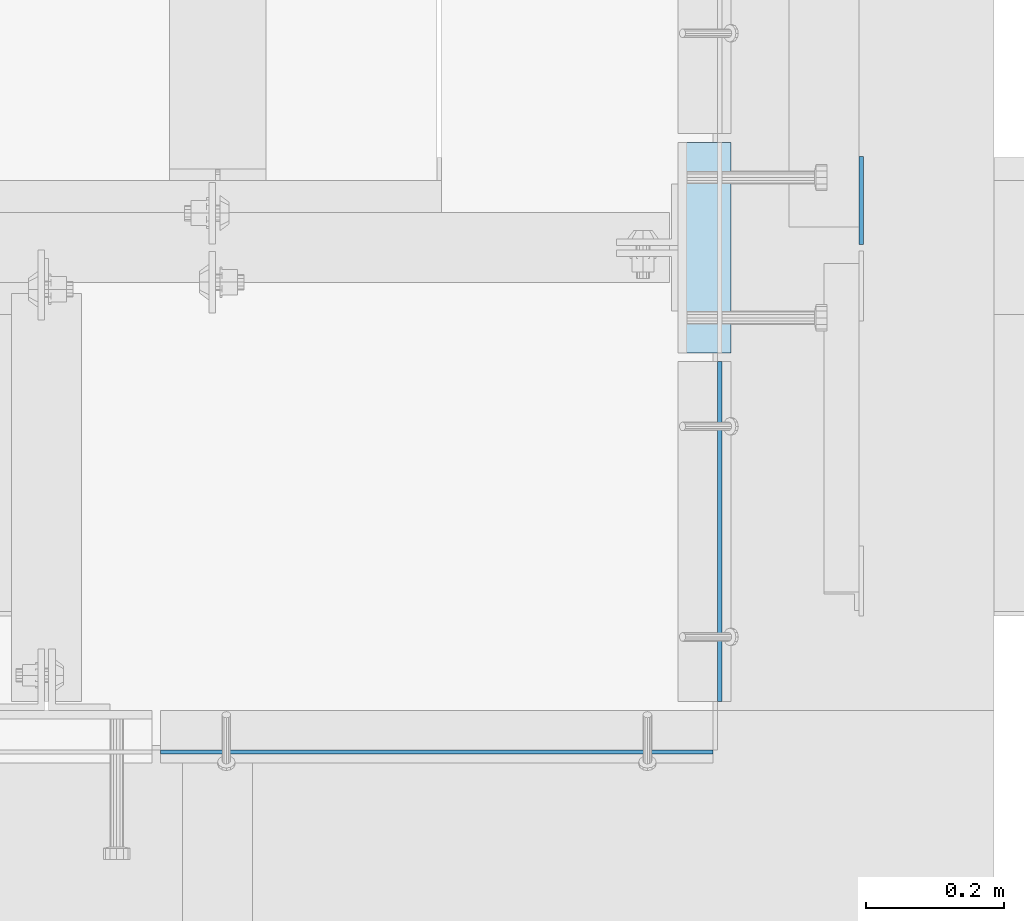
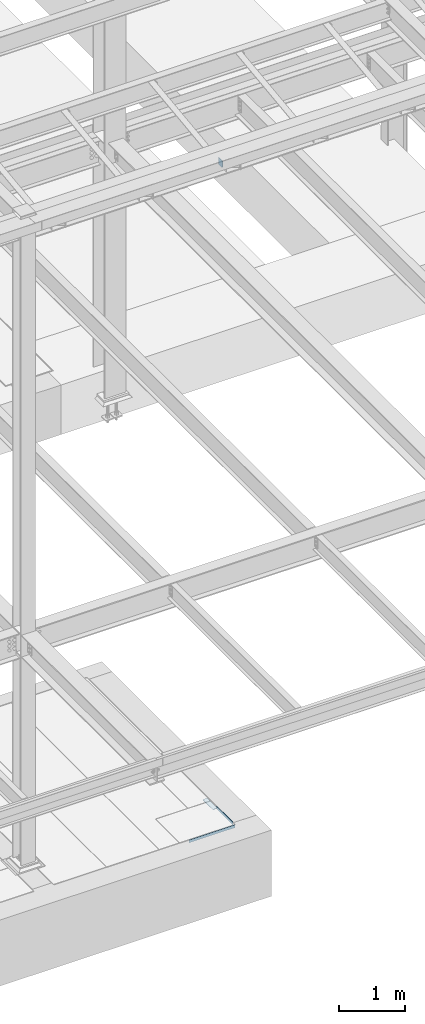
# One storey, part 3083 of 3843: 4 plates, 4 elements without a shape of their own.
"""IFC2X3 building model written with IfcOpenShell, lengths in millimetres."""

from ifc_helpers import new_model, si_unit, frame, origin_with_axes, place, context, subcontext, project, spatial, faceted_brep, material, type_object, element, aggregate, save


model = new_model("IFC2X3")

# Units and contexts
model_context = context("Model", 3, precision=1e-05, world=origin_with_axes())
body_context = subcontext(model_context, "Body", "Model", "MODEL_VIEW")
ifc_project = project(units=[si_unit("LENGTHUNIT", "METRE", prefix="MILLI"), si_unit("AREAUNIT", "SQUARE_METRE"), si_unit("VOLUMEUNIT", "CUBIC_METRE"), si_unit("MASSUNIT", "GRAM", prefix="KILO"), si_unit("TIMEUNIT", "SECOND"), si_unit("PLANEANGLEUNIT", "RADIAN"), si_unit("SOLIDANGLEUNIT", "STERADIAN"), si_unit("THERMODYNAMICTEMPERATUREUNIT", "DEGREE_CELSIUS"), si_unit("LUMINOUSINTENSITYUNIT", "LUMEN")], contexts=[model_context])

# Site, building, storey
site_placement = place(None, origin_with_axes())
site = spatial("IfcSite", under=ifc_project, at=site_placement, CompositionType="ELEMENT")
building_placement = place(site_placement, origin_with_axes())
building = spatial("IfcBuilding", under=site, at=building_placement, Name="Undefined", CompositionType="ELEMENT")
storey_placement = place(building_placement, origin_with_axes())
storey = spatial("IfcBuildingStorey", under=building, at=storey_placement, Name="Undefined", CompositionType="ELEMENT", Elevation=0.0)

# Assembly, plate
assembly_1_placement = place(storey_placement, origin_with_axes())
assembly_1 = element("IfcElementAssembly", 1, at=assembly_1_placement, inside=storey, Name="EMBED PLATE", AssemblyPlace="NOTDEFINED", PredefinedType="RIGID_FRAME")
ifc_material_1 = material(Name="STEEL/A36")
plate_type_1 = type_object("IfcPlateType", PredefinedType="NOTDEFINED")
plate_1_placement = place(assembly_1_placement, frame((65843.15, 14846.3, 30426.025), z_axis=(0.0, 1.0, 0.0), x_axis=(1.0, 0.0, 0.0)))
plate_1 = element("IfcPlate", 2, at=plate_1_placement, type_object=plate_type_1, material=ifc_material_1, Name="PLATE", context=body_context, shape_type="Brep", body=[
    faceted_brep([(0.0, -3.17499999999927, 0.0), (0.0, -3.17499999999927, 304.800000000003), (0.0, 3.17499999999927, 304.800000000003), (0.0, 3.17499999999927, 0.0), (76.1999999999971, -3.17499999999927, 304.799999999996), (76.1999999999971, 3.17499999999927, 304.799999999996), (76.1999999999971, -3.17499999999927, 0.0), (76.1999999999971, 3.17499999999927, 0.0)], [[[0, 1, 2, 3]], [[1, 4, 5, 2]], [[4, 6, 7, 5]], [[6, 0, 3, 7]], [[5, 7, 3, 2]], [[6, 4, 1, 0]]]),
])
aggregate(assembly_1, [plate_1])

assembly_2_placement = place(storey_placement, origin_with_axes())
assembly_2 = element("IfcElementAssembly", 3, at=assembly_2_placement, inside=storey, Name="ANGLE", AssemblyPlace="NOTDEFINED", PredefinedType="RIGID_FRAME")
plate_type_2 = type_object("IfcPlateType", PredefinedType="NOTDEFINED")
plate_2_placement = place(assembly_2_placement, frame((65903.4750270596, 14341.4753869007, 30429.2000030518), z_axis=(0.0, 0.999999999997942, -2.02899998962774e-06), x_axis=(0.0, 2.02899999567308e-06, 0.999999999997942)))
plate_2 = element("IfcPlate", 4, at=plate_2_placement, type_object=plate_type_2, material=ifc_material_1, Name="PLATE", context=body_context, shape_type="Brep", body=[
    faceted_brep([(0.0, -3.17499999999927, 0.0), (0.000990709220786812, -3.17500000288419, 492.1250000001), (0.000990709220786812, 3.17499999712163, 492.125000000102), (0.0, 3.17499999999927, 0.0), (50.8009872442017, -3.17500000288419, 492.124938964971), (50.8009872442017, 3.17499999712163, 492.124938964973), (50.7999954217848, -3.17499999999563, -7.27595761418343e-12), (50.7999954217848, 3.17500000001019, -1.09139364212751e-11)], [[[0, 1, 2, 3]], [[1, 4, 5, 2]], [[4, 6, 7, 5]], [[6, 0, 3, 7]], [[5, 7, 3, 2]], [[6, 4, 1, 0]]]),
])
aggregate(assembly_2, [plate_2])

assembly_3_placement = place(storey_placement, origin_with_axes())
assembly_3 = element("IfcElementAssembly", 5, at=assembly_3_placement, inside=storey, Name="ANGLE", AssemblyPlace="NOTDEFINED", PredefinedType="RIGID_FRAME")
plate_3_placement = place(assembly_3_placement, frame((65093.8500173613, 14268.4495462026, 30429.2000030518), z_axis=(1.0, 0.0, 0.0), x_axis=(0.0, 0.0, 1.0)))
plate_3 = element("IfcPlate", 6, at=plate_3_placement, type_object=plate_type_2, material=ifc_material_1, Name="PLATE", context=body_context, shape_type="Brep", body=[
    faceted_brep([(0.0, -3.17499999999927, 0.0), (-1.66381905728485e-05, -3.17500000000291, 800.100048828994), (-1.66381905728485e-05, 3.17499999999927, 800.100048828972), (0.0, 3.17499999999927, 0.0), (50.799981204138, -3.17500000000291, 800.100048829168), (50.799981204138, 3.17499999999927, 800.100048829139), (50.7999954217848, -3.17499999999563, -7.27595761418343e-12), (50.7999954217848, 3.17500000001019, -1.09139364212751e-11)], [[[0, 1, 2, 3]], [[1, 4, 5, 2]], [[4, 6, 7, 5]], [[6, 0, 3, 7]], [[5, 7, 3, 2]], [[6, 4, 1, 0]]]),
])
aggregate(assembly_3, [plate_3])

assembly_4_placement = place(storey_placement, origin_with_axes())
assembly_4 = element("IfcElementAssembly", 7, at=assembly_4_placement, inside=storey, Name="BEAM", AssemblyPlace="NOTDEFINED", PredefinedType="RIGID_FRAME")
ifc_material_2 = material(Name="STEEL/A572-50")
plate_type_3 = type_object("IfcPlateType", PredefinedType="NOTDEFINED")
plate_4_placement = place(assembly_4_placement, frame((66108.2625, 15003.4625, 42197.3375), z_axis=(0.0, 0.0, -1.0), x_axis=(0.0, 1.0, 0.0)))
plate_4 = element("IfcPlate", 8, at=plate_4_placement, type_object=plate_type_3, material=ifc_material_2, Name="PLATE", context=body_context, shape_type="Brep", body=[
    faceted_brep([(0.0, -3.17499999999927, 0.0), (0.0, -3.17500000000291, 104.775000000001), (0.0, 3.17500000000291, 104.775000000001), (0.0, 3.17499999999927, 0.0), (22.2249999999985, -3.17500000000291, 127.0), (22.2249999999985, 3.17500000000291, 127.0), (127.0, -3.17500000000291, 127.0), (127.0, 3.17500000000291, 127.0), (127.0, -3.17500000000291, 0.0), (127.0, 3.17500000000291, 0.0)], [[[0, 1, 2, 3]], [[1, 4, 5, 2]], [[4, 6, 7, 5]], [[6, 8, 9, 7]], [[8, 0, 3, 9]], [[5, 7, 9, 3, 2]], [[8, 6, 4, 1, 0]]]),
])
aggregate(assembly_4, [plate_4])

save(model, "model.ifc")
